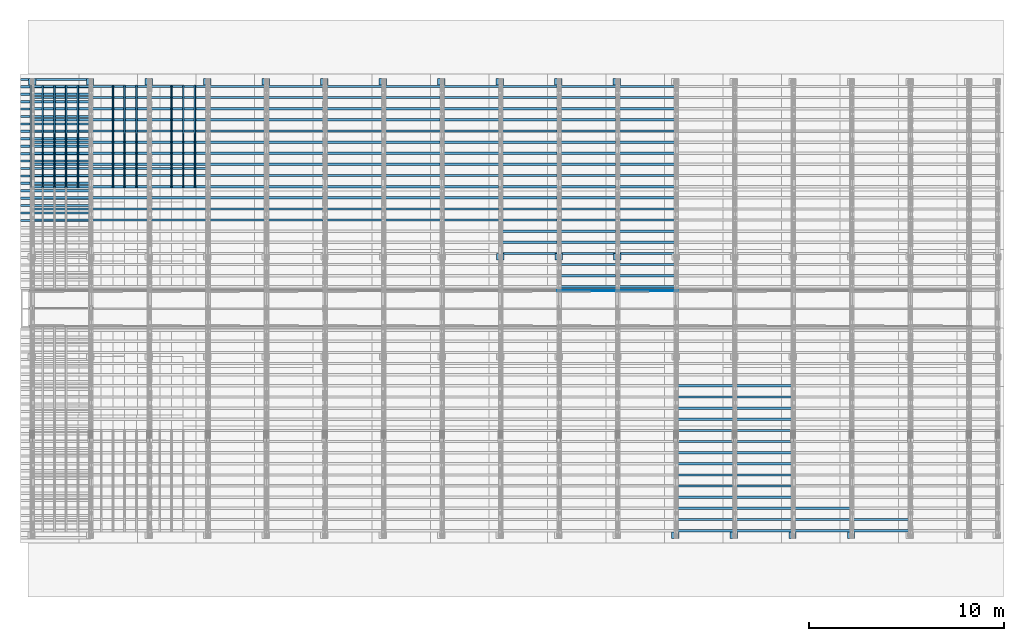
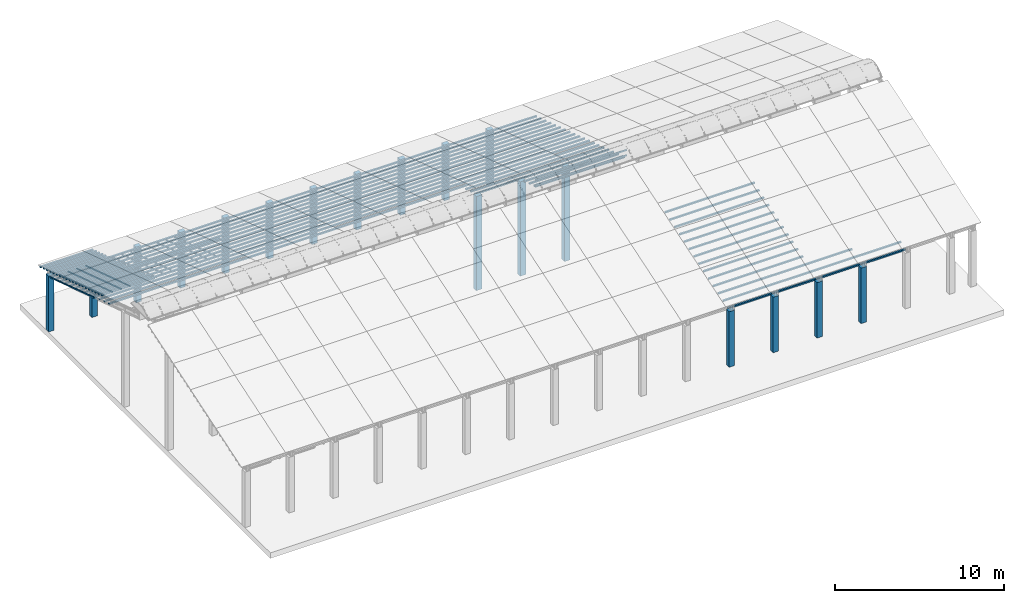
# One storey, part 3 of 385: 248 columns.
"""IFC2X3 building model written with IfcOpenShell, lengths in millimetres."""

from ifc_helpers import new_model, entity, si_unit, converted_unit, derived_unit, direction, frame, frame_2d, origin, origin_2d_with_axis, place, context, subcontext, project, spatial, rectangle, extrude, boolean, source, transform, mapped, material, type_object, type_shapes, element, save


model = new_model("IFC2X3")

# Units and contexts
model_context = context("Model", 3, precision=0.01, world=origin(), true_north=direction((6.12303176911189e-17, 1.0)))
body_context = subcontext(model_context, "Body", "Model", "MODEL_VIEW")
ifc_project = project(units=[si_unit("LENGTHUNIT", "METRE", prefix="MILLI"), si_unit("AREAUNIT", "SQUARE_METRE"), si_unit("VOLUMEUNIT", "CUBIC_METRE"), converted_unit("PLANEANGLEUNIT", "DEGREE", entity("IfcRatioMeasure", 0.0174532925199433), si_unit("PLANEANGLEUNIT", "RADIAN"), dimensions=[0, 0, 0, 0, 0, 0, 0]), si_unit("MASSUNIT", "GRAM", prefix="KILO"), derived_unit("MASSDENSITYUNIT", [(si_unit("MASSUNIT", "GRAM", prefix="KILO"), 1), (si_unit("LENGTHUNIT", "METRE"), -3)]), si_unit("TIMEUNIT", "SECOND"), si_unit("FREQUENCYUNIT", "HERTZ"), si_unit("THERMODYNAMICTEMPERATUREUNIT", "DEGREE_CELSIUS"), derived_unit("THERMALTRANSMITTANCEUNIT", [(si_unit("MASSUNIT", "GRAM", prefix="KILO"), 1), (si_unit("THERMODYNAMICTEMPERATUREUNIT", "KELVIN"), -1), (si_unit("TIMEUNIT", "SECOND"), -3)]), derived_unit("VOLUMETRICFLOWRATEUNIT", [(si_unit("LENGTHUNIT", "METRE"), 3), (si_unit("TIMEUNIT", "SECOND"), -1)]), si_unit("ELECTRICCURRENTUNIT", "AMPERE"), si_unit("ELECTRICVOLTAGEUNIT", "VOLT"), si_unit("POWERUNIT", "WATT"), si_unit("FORCEUNIT", "NEWTON", prefix="KILO"), si_unit("ILLUMINANCEUNIT", "LUX"), si_unit("LUMINOUSFLUXUNIT", "LUMEN"), si_unit("LUMINOUSINTENSITYUNIT", "CANDELA"), derived_unit("USERDEFINED", [(si_unit("MASSUNIT", "GRAM", prefix="KILO"), -1), (si_unit("LENGTHUNIT", "METRE"), -2), (si_unit("TIMEUNIT", "SECOND"), 3), (si_unit("LUMINOUSFLUXUNIT", "LUMEN"), 1)]), derived_unit("LINEARVELOCITYUNIT", [(si_unit("LENGTHUNIT", "METRE"), 1), (si_unit("TIMEUNIT", "SECOND"), -1)]), si_unit("PRESSUREUNIT", "PASCAL"), derived_unit("USERDEFINED", [(si_unit("LENGTHUNIT", "METRE"), -2), (si_unit("MASSUNIT", "GRAM", prefix="KILO"), 1), (si_unit("TIMEUNIT", "SECOND"), -2)])], contexts=[model_context])

# Site, building, storey
site_placement = place(None, origin())
site = spatial("IfcSite", under=ifc_project, at=site_placement, CompositionType="ELEMENT")
building_placement = place(site_placement, origin())
building = spatial("IfcBuilding", under=site, at=building_placement, CompositionType="ELEMENT")
storey_placement = place(building_placement, origin())
storey = spatial("IfcBuildingStorey", under=building, at=storey_placement, Name="Default", CompositionType="ELEMENT", Elevation=0.0)

# Columns
ifc_material_1 = material()
column_type_1 = type_object("IfcColumnType", Name="200x200", PredefinedType="COLUMN")
shared_shape_1 = source(origin(), body_context, "Body", "SweptSolid", [
    extrude(rectangle(XDim=379.999999999997, YDim=320.000000000004, at=origin_2d_with_axis()), frame((160.0, 300.0, -4000.0), z_axis=(0.0, 0.0, 1.0), x_axis=(0.0, -1.0, 0.0)), (0.0, 0.0, 1.0), 4000.0),
])
type_shapes(column_type_1, [shared_shape_1])
for number, where, z_axis, x_axis, name in (
    (1, (576.250000000001, 26180.0, 0.0), (0.0, 0.0, 1.0), (0.0, 1.0, 0.0), "V:200x200"),
    (2, (3535.0, 26180.0, 0.0), (0.0, 0.0, 1.0), (0.0, 1.0, 0.0), "V:200x200"),
    (3, (6535.0, 26180.0, 0.0), (0.0, 0.0, 1.0), (0.0, 1.0, 0.0), "V:200x200"),
    (4, (9535.0, 26180.0, 0.0), (0.0, 0.0, 1.0), (0.0, 1.0, 0.0), "V:200x200"),
    (5, (12535.0, 26180.0, 0.0), (0.0, 0.0, 1.0), (0.0, 1.0, 0.0), "V:200x200"),
    (6, (15535.0, 26180.0, 0.0), (0.0, 0.0, 1.0), (0.0, 1.0, 0.0), "V:200x200"),
    (7, (18535.0, 26180.0, 0.0), (0.0, 0.0, 1.0), (0.0, 1.0, 0.0), "V:200x200"),
    (8, (21535.0, 26180.0, 0.0), (0.0, 0.0, 1.0), (0.0, 1.0, 0.0), "V:200x200"),
    (9, (24535.0, 26180.0, 0.0), (0.0, 0.0, 1.0), (0.0, 1.0, 0.0), "V:200x200"),
    (10, (27535.0, 26180.0, 0.0), (0.0, 0.0, 1.0), (0.0, 1.0, 0.0), "V:200x200"),
    (11, (30535.0, 26180.0, 0.0), (0.0, 0.0, 1.0), (0.0, 1.0, 0.0), "V:200x200"),
    (12, (33535.0, 2940.0, 0.0), (0.0, 0.0, 1.0), (0.0, 1.0, 0.0), "V:200x200"),
    (13, (36535.0, 2940.0, 0.0), (0.0, 0.0, 1.0), (0.0, 1.0, 0.0), "V:200x200"),
    (14, (39535.0, 2940.0, 0.0), (0.0, 0.0, 1.0), (0.0, 1.0, 0.0), "V:200x200"),
    (15, (42535.0, 2940.0, 0.0), (0.0, 0.0, 1.0), (0.0, 1.0, 0.0), "V:200x200"),
):
    element("IfcColumn", number, at=place(storey_placement, frame(where, z_axis=z_axis, x_axis=x_axis)), inside=storey, type_object=column_type_1, material=ifc_material_1, Name=name, ObjectType="V:200x200", context=body_context, shape_type="MappedRepresentation", body=[
        mapped(shared_shape_1, transform((0.0, 0.0, 0.0), scale=1.0)),
    ])
column_type_2 = type_object("IfcColumnType", Name="200x200", PredefinedType="COLUMN")
shared_shape_2 = source(origin(), body_context, "Body", "SweptSolid", [
    extrude(rectangle(XDim=379.999999999997, YDim=320.000000000004, at=origin_2d_with_axis()), frame((160.0, 300.0, -4000.0), z_axis=(0.0, 0.0, 1.0), x_axis=(0.0, -1.0, 0.0)), (0.0, 0.0, 1.0), 6794.3),
])
type_shapes(column_type_2, [shared_shape_2])
for number, where, z_axis, x_axis, name in (
    (16, (24550.0, 17220.0, 0.0), (0.0, 0.0, 1.0), (0.0, 1.0, 0.0), "V:200x200"),
    (17, (27550.0, 17220.0, 0.0), (0.0, 0.0, 1.0), (0.0, 1.0, 0.0), "V:200x200"),
    (18, (30550.0, 17220.0, 0.0), (0.0, 0.0, 1.0), (0.0, 1.0, 0.0), "V:200x200"),
):
    element("IfcColumn", number, at=place(storey_placement, frame(where, z_axis=z_axis, x_axis=x_axis)), inside=storey, type_object=column_type_2, material=ifc_material_1, Name=name, ObjectType="V:200x200", context=body_context, shape_type="MappedRepresentation", body=[
        mapped(shared_shape_2, transform((0.0, 0.0, 0.0), scale=1.0)),
    ])
ifc_material_2 = material(Name="2")
column_type_3 = type_object("IfcColumnType", Name="100x70", PredefinedType="COLUMN")
shared_shape_3 = source(origin(), body_context, "Body", "CSG", [
    boolean("DIFFERENCE", extrude(rectangle(XDim=3612.2975905123, YDim=116.736841236773, at=origin_2d_with_axis()), frame((1806.14879525615, 145.11006420193, -28.6286403914129)), (0.0, 0.0, 1.0), 97.4756555803792), extrude(rectangle(XDim=70.0000000018648, YDim=100.00000000027, at=frame_2d((0.0, 3.5527136788005e-15), x_axis=(0.0, 1.0))), frame((3612.2975905123, 145.11006420193, 20.1091873987768), z_axis=(1.0, 0.0, 0.0), x_axis=(0.0, 0.951056516293611, -0.309016994379696)), (0.0, 0.0, -1.0), 3612.2975905123)),
])
type_shapes(column_type_3, [shared_shape_3])
for number, where, name in (
    (19, (-325.267643336502, 26317.9847769485, 628.753486115588), "H_28_35_gradi:100x70"),
    (20, (-325.267643336503, 25937.5621704304, 752.360283865566), "H_28_35_gradi:100x70"),
    (21, (-325.267643336503, 25557.1395639124, 875.967081615544), "H_28_35_gradi:100x70"),
    (22, (-325.267643336504, 25176.7169573943, 999.573879365521), "H_28_35_gradi:100x70"),
    (23, (-325.267643336505, 24796.2943508762, 1123.1806771155), "H_28_35_gradi:100x70"),
    (24, (-325.267643336505, 24415.8717443582, 1246.78747486548), "H_28_35_gradi:100x70"),
    (25, (-325.267643336506, 24035.4491378401, 1370.39427261545), "H_28_35_gradi:100x70"),
    (26, (-325.267643336507, 23655.0265313221, 1494.00107036543), "H_28_35_gradi:100x70"),
    (27, (-325.267643336507, 23274.603924804, 1617.60786811541), "H_28_35_gradi:100x70"),
    (28, (-325.267643336508, 22894.1813182859, 1741.21466586539), "H_28_35_gradi:100x70"),
    (29, (-325.267643336509, 22513.7587117679, 1864.82146361537), "H_28_35_gradi:100x70"),
    (30, (-325.267643336509, 22133.3361052498, 1988.42826136534), "H_28_35_gradi:100x70"),
    (31, (-325.26764333651, 21752.9134987318, 2112.03505911532), "H_28_35_gradi:100x70"),
    (32, (-325.26764333651, 21372.4908922137, 2235.6418568653), "H_28_35_gradi:100x70"),
    (33, (-325.267643336511, 20992.0682856956, 2359.24865461528), "H_28_35_gradi:100x70"),
    (34, (-325.267643336512, 20611.6456791776, 2482.85545236525), "H_28_35_gradi:100x70"),
    (35, (-325.267643336512, 20231.2230726595, 2606.46225011523), "H_28_35_gradi:100x70"),
    (36, (-325.267643336513, 19850.8004661415, 2730.06904786521), "H_28_35_gradi:100x70"),
    (37, (-325.267643336514, 19470.3778596234, 2853.67584561518), "H_28_35_gradi:100x70"),
    (38, (-325.267643336514, 19089.9552531053, 2977.28264336516), "H_28_35_gradi:100x70"),
    (39, (2674.73235666349, 21752.9134987317, 2112.03505911532), "H_28_35_gradi:100x70"),
    (40, (5674.73235666349, 21752.9134987317, 2112.03505911532), "H_28_35_gradi:100x70"),
):
    element("IfcColumn", number, at=place(storey_placement, frame(where)), inside=storey, type_object=column_type_3, material=ifc_material_2, Name=name, ObjectType="H_28_35_gradi:100x70", context=body_context, shape_type="MappedRepresentation", body=[
        mapped(shared_shape_3, transform((0.0, 0.0, 0.0), scale=1.0)),
    ])
column_type_4 = type_object("IfcColumnType", Name="100x70", PredefinedType="COLUMN")
shared_shape_4 = source(origin(), body_context, "Body", "CSG", [
    boolean("DIFFERENCE", extrude(rectangle(XDim=3112.0299471758, YDim=116.736841236773, at=origin_2d_with_axis()), frame((1556.0149735879, 145.11006420193, -28.6286403914128)), (0.0, 0.0, 1.0), 97.4756555803792), extrude(rectangle(XDim=70.0000000018648, YDim=100.00000000027, at=frame_2d((0.0, 3.5527136788005e-15), x_axis=(0.0, 1.0))), frame((3112.0299471758, 145.11006420193, 20.1091873987768), z_axis=(1.0, 0.0, 0.0), x_axis=(0.0, 0.951056516293611, -0.309016994379696)), (0.0, 0.0, -1.0), 3112.0299471758)),
])
type_shapes(column_type_4, [shared_shape_4])
column_placement = place(storey_placement, frame((175.0, 25956.5215151797, -37.9453157522206)))
element("IfcColumn", 41, at=column_placement, inside=storey, type_object=column_type_4, material=ifc_material_2, Name="H_28_35_gradi:100x70", ObjectType="H_28_35_gradi:100x70", context=body_context, shape_type="MappedRepresentation", body=[
    mapped(shared_shape_4, transform((0.0, 0.0, 0.0), scale=1.0)),
])
for number, where, name in (
    (42, (175.0, 25385.8876054039, 147.464880876897), "H_28_35_gradi:100x70"),
    (43, (175.0, 24815.253695627, 332.8750775022), "H_28_35_gradi:100x70"),
    (44, (175.0, 24244.6197858499, 518.285274127168), "H_28_35_gradi:100x70"),
    (45, (175.0, 23673.9858760728, 703.695470752224), "H_28_35_gradi:100x70"),
    (46, (175.0, 23103.3519662957, 889.105667377245), "H_28_35_gradi:100x70"),
    (47, (175.0, 22532.7180565186, 1074.51586400227), "H_28_35_gradi:100x70"),
    (48, (175.0, 21962.0841467416, 1259.92606062729), "H_28_35_gradi:100x70"),
    (49, (175.0, 21391.4502369645, 1445.33625725232), "H_28_35_gradi:100x70"),
    (50, (175.0, 20820.8163271874, 1630.74645387734), "H_28_35_gradi:100x70"),
    (51, (175.0, 20250.1824174103, 1816.15665050237), "H_28_35_gradi:100x70"),
    (52, (175.0, 19679.5485076333, 2001.56684712739), "H_28_35_gradi:100x70"),
    (53, (175.0, 19108.9145978562, 2186.97704375242), "H_28_35_gradi:100x70"),
):
    element("IfcColumn", number, at=place(building_placement, frame(where)), inside=storey, type_object=column_type_4, material=ifc_material_2, Name=name, ObjectType="H_28_35_gradi:100x70", context=body_context, shape_type="MappedRepresentation", body=[
        mapped(shared_shape_4, transform((0.0, 0.0, 0.0), scale=1.0)),
    ])
for number, where, name in (
    (54, (3175.0, 25956.5215151797, -37.9453157522206), "H_28_35_gradi:100x70"),
    (55, (3175.0, 25385.8876054039, 147.464880876897), "H_28_35_gradi:100x70"),
    (56, (3175.0, 24815.2536956269, 332.8750775022), "H_28_35_gradi:100x70"),
    (57, (3175.0, 24244.6197858498, 518.285274127168), "H_28_35_gradi:100x70"),
    (58, (3175.0, 23673.9858760728, 703.695470752224), "H_28_35_gradi:100x70"),
    (59, (3175.0, 23103.3519662957, 889.105667377245), "H_28_35_gradi:100x70"),
    (60, (3175.0, 22532.7180565186, 1074.51586400227), "H_28_35_gradi:100x70"),
    (61, (3175.0, 21962.0841467416, 1259.92606062729), "H_28_35_gradi:100x70"),
    (62, (3175.0, 21391.4502369645, 1445.33625725232), "H_28_35_gradi:100x70"),
    (63, (3175.0, 20820.8163271874, 1630.74645387734), "H_28_35_gradi:100x70"),
    (64, (3175.0, 20250.1824174103, 1816.15665050237), "H_28_35_gradi:100x70"),
    (65, (3175.0, 19679.5485076333, 2001.56684712739), "H_28_35_gradi:100x70"),
    (66, (3175.0, 19108.9145978562, 2186.97704375242), "H_28_35_gradi:100x70"),
    (67, (6175.0, 25956.5215151797, -37.9453157522206), "H_28_35_gradi:100x70"),
    (68, (6175.0, 25385.8876054039, 147.464880876897), "H_28_35_gradi:100x70"),
    (69, (6175.0, 24815.2536956269, 332.8750775022), "H_28_35_gradi:100x70"),
    (70, (6175.0, 24244.6197858498, 518.285274127168), "H_28_35_gradi:100x70"),
    (71, (6175.0, 23673.9858760728, 703.695470752224), "H_28_35_gradi:100x70"),
    (72, (6175.0, 23103.3519662957, 889.105667377245), "H_28_35_gradi:100x70"),
    (73, (6175.0, 22532.7180565186, 1074.51586400227), "H_28_35_gradi:100x70"),
    (74, (6175.0, 21962.0841467416, 1259.92606062729), "H_28_35_gradi:100x70"),
    (75, (6175.0, 21391.4502369645, 1445.33625725232), "H_28_35_gradi:100x70"),
    (76, (6175.0, 20820.8163271874, 1630.74645387734), "H_28_35_gradi:100x70"),
    (77, (6175.0, 20250.1824174103, 1816.15665050237), "H_28_35_gradi:100x70"),
    (78, (6175.0, 19679.5485076333, 2001.56684712739), "H_28_35_gradi:100x70"),
    (79, (6175.0, 19108.9145978562, 2186.97704375242), "H_28_35_gradi:100x70"),
    (80, (9175.0, 25956.5215151797, -37.9453157522206), "H_28_35_gradi:100x70"),
    (81, (9175.0, 25385.8876054039, 147.464880876897), "H_28_35_gradi:100x70"),
    (82, (9175.0, 24815.2536956269, 332.8750775022), "H_28_35_gradi:100x70"),
    (83, (9175.0, 24244.6197858498, 518.285274127168), "H_28_35_gradi:100x70"),
    (84, (9175.0, 23673.9858760728, 703.695470752224), "H_28_35_gradi:100x70"),
    (85, (9175.0, 23103.3519662957, 889.105667377245), "H_28_35_gradi:100x70"),
    (86, (9175.0, 22532.7180565186, 1074.51586400227), "H_28_35_gradi:100x70"),
    (87, (9175.0, 21962.0841467415, 1259.92606062729), "H_28_35_gradi:100x70"),
    (88, (9175.0, 21391.4502369645, 1445.33625725232), "H_28_35_gradi:100x70"),
    (89, (9175.0, 20820.8163271874, 1630.74645387734), "H_28_35_gradi:100x70"),
    (90, (9175.0, 20250.1824174103, 1816.15665050237), "H_28_35_gradi:100x70"),
    (91, (9175.0, 19679.5485076332, 2001.56684712739), "H_28_35_gradi:100x70"),
    (92, (9175.0, 19108.9145978562, 2186.97704375242), "H_28_35_gradi:100x70"),
    (93, (12175.0, 25956.5215151796, -37.9453157522206), "H_28_35_gradi:100x70"),
    (94, (12175.0, 25385.8876054039, 147.464880876897), "H_28_35_gradi:100x70"),
    (95, (12175.0, 24815.2536956269, 332.8750775022), "H_28_35_gradi:100x70"),
    (96, (12175.0, 24244.6197858498, 518.285274127168), "H_28_35_gradi:100x70"),
    (97, (12175.0, 23673.9858760728, 703.695470752224), "H_28_35_gradi:100x70"),
    (98, (12175.0, 23103.3519662957, 889.105667377245), "H_28_35_gradi:100x70"),
    (99, (12175.0, 22532.7180565186, 1074.51586400227), "H_28_35_gradi:100x70"),
    (100, (12175.0, 21962.0841467415, 1259.92606062729), "H_28_35_gradi:100x70"),
    (101, (12175.0, 21391.4502369645, 1445.33625725232), "H_28_35_gradi:100x70"),
    (102, (12175.0, 20820.8163271874, 1630.74645387734), "H_28_35_gradi:100x70"),
    (103, (12175.0, 20250.1824174103, 1816.15665050237), "H_28_35_gradi:100x70"),
    (104, (12175.0, 19679.5485076332, 2001.56684712739), "H_28_35_gradi:100x70"),
    (105, (12175.0, 19108.9145978562, 2186.97704375242), "H_28_35_gradi:100x70"),
    (106, (15175.0, 25956.5215151796, -37.9453157522206), "H_28_35_gradi:100x70"),
    (107, (15175.0, 25385.8876054039, 147.464880876897), "H_28_35_gradi:100x70"),
    (108, (15175.0, 24815.2536956269, 332.8750775022), "H_28_35_gradi:100x70"),
    (109, (15175.0, 24244.6197858498, 518.285274127168), "H_28_35_gradi:100x70"),
    (110, (15175.0, 23673.9858760728, 703.695470752224), "H_28_35_gradi:100x70"),
    (111, (15175.0, 23103.3519662957, 889.105667377245), "H_28_35_gradi:100x70"),
    (112, (15175.0, 22532.7180565186, 1074.51586400227), "H_28_35_gradi:100x70"),
    (113, (15175.0, 21962.0841467415, 1259.92606062729), "H_28_35_gradi:100x70"),
    (114, (15175.0, 21391.4502369645, 1445.33625725232), "H_28_35_gradi:100x70"),
    (115, (15175.0, 20820.8163271874, 1630.74645387734), "H_28_35_gradi:100x70"),
    (116, (15175.0, 20250.1824174103, 1816.15665050237), "H_28_35_gradi:100x70"),
    (117, (15175.0, 19679.5485076332, 2001.56684712739), "H_28_35_gradi:100x70"),
    (118, (15175.0, 19108.9145978562, 2186.97704375242), "H_28_35_gradi:100x70"),
    (119, (18175.0, 25956.5215151796, -37.9453157522206), "H_28_35_gradi:100x70"),
    (120, (18175.0, 25385.8876054039, 147.464880876897), "H_28_35_gradi:100x70"),
    (121, (18175.0, 24815.2536956269, 332.8750775022), "H_28_35_gradi:100x70"),
    (122, (18175.0, 24244.6197858498, 518.285274127168), "H_28_35_gradi:100x70"),
    (123, (18175.0, 23673.9858760727, 703.695470752224), "H_28_35_gradi:100x70"),
    (124, (18175.0, 23103.3519662957, 889.105667377245), "H_28_35_gradi:100x70"),
    (125, (18175.0, 22532.7180565186, 1074.51586400227), "H_28_35_gradi:100x70"),
    (126, (18175.0, 21962.0841467415, 1259.92606062729), "H_28_35_gradi:100x70"),
    (127, (18175.0, 21391.4502369644, 1445.33625725232), "H_28_35_gradi:100x70"),
    (128, (18175.0, 20820.8163271874, 1630.74645387734), "H_28_35_gradi:100x70"),
    (129, (18175.0, 20250.1824174103, 1816.15665050237), "H_28_35_gradi:100x70"),
    (130, (18175.0, 19679.5485076332, 2001.56684712739), "H_28_35_gradi:100x70"),
    (131, (18175.0, 19108.9145978561, 2186.97704375242), "H_28_35_gradi:100x70"),
    (132, (21175.0, 25956.5215151796, -37.9453157522206), "H_28_35_gradi:100x70"),
    (133, (21175.0, 25385.8876054039, 147.464880876897), "H_28_35_gradi:100x70"),
    (134, (21175.0, 24815.2536956269, 332.8750775022), "H_28_35_gradi:100x70"),
    (135, (21175.0, 24244.6197858498, 518.285274127168), "H_28_35_gradi:100x70"),
    (136, (21175.0, 23673.9858760727, 703.695470752224), "H_28_35_gradi:100x70"),
    (137, (21175.0, 23103.3519662957, 889.105667377245), "H_28_35_gradi:100x70"),
    (138, (21175.0, 22532.7180565186, 1074.51586400227), "H_28_35_gradi:100x70"),
    (139, (21175.0, 21962.0841467415, 1259.92606062729), "H_28_35_gradi:100x70"),
    (140, (21175.0, 21391.4502369644, 1445.33625725232), "H_28_35_gradi:100x70"),
    (141, (21175.0, 20820.8163271874, 1630.74645387734), "H_28_35_gradi:100x70"),
    (142, (21175.0, 20250.1824174103, 1816.15665050237), "H_28_35_gradi:100x70"),
    (143, (21175.0, 19679.5485076332, 2001.56684712739), "H_28_35_gradi:100x70"),
    (144, (21175.0, 19108.9145978561, 2186.97704375242), "H_28_35_gradi:100x70"),
    (145, (24175.0, 25956.5215151796, -37.9453157522206), "H_28_35_gradi:100x70"),
    (146, (24175.0, 25385.8876054039, 147.464880876897), "H_28_35_gradi:100x70"),
    (147, (24175.0, 24815.2536956269, 332.8750775022), "H_28_35_gradi:100x70"),
    (148, (24175.0, 24244.6197858498, 518.285274127168), "H_28_35_gradi:100x70"),
    (149, (24175.0, 23673.9858760727, 703.695470752224), "H_28_35_gradi:100x70"),
    (150, (24175.0, 23103.3519662957, 889.105667377245), "H_28_35_gradi:100x70"),
    (151, (24175.0, 22532.7180565186, 1074.51586400227), "H_28_35_gradi:100x70"),
    (152, (24175.0, 21962.0841467415, 1259.92606062729), "H_28_35_gradi:100x70"),
    (153, (24175.0, 21391.4502369644, 1445.33625725232), "H_28_35_gradi:100x70"),
    (154, (24175.0, 20820.8163271873, 1630.74645387734), "H_28_35_gradi:100x70"),
    (155, (24175.0, 20250.1824174103, 1816.15665050237), "H_28_35_gradi:100x70"),
    (156, (24175.0, 19679.5485076332, 2001.56684712739), "H_28_35_gradi:100x70"),
    (157, (24175.0, 19108.9145978561, 2186.97704375242), "H_28_35_gradi:100x70"),
    (158, (24175.0, 18538.2806880791, 2372.38724037744), "H_28_35_gradi:100x70"),
    (159, (24175.0, 17967.646778302, 2557.79743700247), "H_28_35_gradi:100x70"),
    (160, (24175.0, 17397.0128685249, 2743.20763362749), "H_28_35_gradi:100x70"),
    (161, (27175.0, 25956.5215151796, -37.9453157522206), "H_28_35_gradi:100x70"),
    (162, (27175.0, 25385.8876054039, 147.464880876897), "H_28_35_gradi:100x70"),
    (163, (27175.0, 24815.2536956269, 332.8750775022), "H_28_35_gradi:100x70"),
    (164, (27175.0, 24244.6197858498, 518.285274127168), "H_28_35_gradi:100x70"),
    (165, (27175.0, 23673.9858760727, 703.695470752224), "H_28_35_gradi:100x70"),
    (166, (27175.0, 23103.3519662956, 889.105667377245), "H_28_35_gradi:100x70"),
    (167, (27175.0, 22532.7180565186, 1074.51586400227), "H_28_35_gradi:100x70"),
    (168, (27175.0, 21962.0841467415, 1259.92606062729), "H_28_35_gradi:100x70"),
    (169, (27175.0, 21391.4502369644, 1445.33625725232), "H_28_35_gradi:100x70"),
    (170, (27175.0, 20820.8163271873, 1630.74645387734), "H_28_35_gradi:100x70"),
    (171, (27175.0, 20250.1824174103, 1816.15665050237), "H_28_35_gradi:100x70"),
    (172, (27175.0, 19679.5485076332, 2001.56684712739), "H_28_35_gradi:100x70"),
    (173, (27175.0, 19108.9145978561, 2186.97704375242), "H_28_35_gradi:100x70"),
    (174, (27175.0, 18538.280688079, 2372.38724037744), "H_28_35_gradi:100x70"),
    (175, (27175.0, 17967.646778302, 2557.79743700247), "H_28_35_gradi:100x70"),
    (176, (27175.0, 17397.0128685249, 2743.20763362749), "H_28_35_gradi:100x70"),
    (177, (27175.0, 16826.3789587478, 2928.61783025252), "H_28_35_gradi:100x70"),
    (178, (27175.0, 16255.7450489708, 3114.02802687754), "H_28_35_gradi:100x70"),
    (179, (27175.0, 15685.1111391937, 3299.43822350257), "H_28_35_gradi:100x70"),
    (180, (27175.0, 15551.9632269124, 3342.70060271507), "H_28_35_gradi:100x70"),
    (181, (30175.0, 25956.5215151796, -37.9453157522206), "H_28_35_gradi:100x70"),
    (182, (30175.0, 25385.8876054038, 147.464880876897), "H_28_35_gradi:100x70"),
    (183, (30175.0, 24815.2536956269, 332.8750775022), "H_28_35_gradi:100x70"),
    (184, (30175.0, 24244.6197858498, 518.285274127168), "H_28_35_gradi:100x70"),
    (185, (30175.0, 23673.9858760727, 703.695470752224), "H_28_35_gradi:100x70"),
    (186, (30175.0, 23103.3519662956, 889.105667377245), "H_28_35_gradi:100x70"),
    (187, (30175.0, 22532.7180565186, 1074.51586400227), "H_28_35_gradi:100x70"),
    (188, (30175.0, 21962.0841467415, 1259.92606062729), "H_28_35_gradi:100x70"),
    (189, (30175.0, 21391.4502369644, 1445.33625725232), "H_28_35_gradi:100x70"),
    (190, (30175.0, 20820.8163271873, 1630.74645387734), "H_28_35_gradi:100x70"),
    (191, (30175.0, 20250.1824174103, 1816.15665050237), "H_28_35_gradi:100x70"),
    (192, (30175.0, 19679.5485076332, 2001.56684712739), "H_28_35_gradi:100x70"),
    (193, (30175.0, 19108.9145978561, 2186.97704375242), "H_28_35_gradi:100x70"),
    (194, (30175.0, 18538.280688079, 2372.38724037744), "H_28_35_gradi:100x70"),
    (195, (30175.0, 17967.646778302, 2557.79743700247), "H_28_35_gradi:100x70"),
    (196, (30175.0, 17397.0128685249, 2743.20763362749), "H_28_35_gradi:100x70"),
    (197, (30175.0, 16826.3789587478, 2928.61783025252), "H_28_35_gradi:100x70"),
    (198, (30175.0, 16255.7450489707, 3114.02802687754), "H_28_35_gradi:100x70"),
    (199, (30175.0, 15685.1111391937, 3299.43822350257), "H_28_35_gradi:100x70"),
    (200, (30175.0, 15551.9632269124, 3342.70060271507), "H_28_35_gradi:100x70"),
):
    element("IfcColumn", number, at=place(storey_placement, frame(where)), inside=storey, type_object=column_type_4, material=ifc_material_2, Name=name, ObjectType="H_28_35_gradi:100x70", context=body_context, shape_type="MappedRepresentation", body=[
        mapped(shared_shape_4, transform((0.0, 0.0, 0.0), scale=1.0)),
    ])
column_type_5 = type_object("IfcColumnType", Name="45x70", PredefinedType="COLUMN")
shared_shape_5 = source(origin(), body_context, "Body", "SweptSolid", [
    extrude(rectangle(XDim=5484.52420681414, YDim=70.0, at=frame_2d((0.0, 0.0), x_axis=(0.0, 1.0))), frame((2608.04624283455, -237.823014276398, 847.405592983174), z_axis=(-0.309016994374947, 0.0, 0.951056516295154), x_axis=(0.0, 1.0, 0.0)), (0.0, 0.0, 1.0), 44.9999999999777),
])
type_shapes(column_type_5, [shared_shape_5])
for number, where, z_axis, x_axis, name in (
    (201, (447.823014276389, 26156.4255163017, -119.756735629718), (0.0, 0.0, 1.0), (0.0, -1.0, 0.0), "H:45x70"),
    (202, (1047.82301427639, 26156.4255163017, -119.756735629718), (0.0, 0.0, 1.0), (0.0, -1.0, 0.0), "H:45x70"),
    (203, (1647.82301427639, 26156.4255163017, -119.756735629718), (0.0, 0.0, 1.0), (0.0, -1.0, 0.0), "H:45x70"),
    (204, (2247.82301427639, 26156.4255163017, -119.756735629718), (0.0, 0.0, 1.0), (0.0, -1.0, 0.0), "H:45x70"),
    (205, (2847.82301427639, 26156.4255163017, -119.756735629718), (0.0, 0.0, 1.0), (0.0, -1.0, 0.0), "H:45x70"),
    (206, (4647.82301427639, 26156.4255163017, -119.756735629718), (0.0, 0.0, 1.0), (0.0, -1.0, 0.0), "H:45x70"),
    (207, (5247.82301427639, 26156.4255163017, -119.756735629718), (0.0, 0.0, 1.0), (0.0, -1.0, 0.0), "H:45x70"),
    (208, (5847.82301427639, 26156.4255163017, -119.756735629718), (0.0, 0.0, 1.0), (0.0, -1.0, 0.0), "H:45x70"),
    (209, (7647.82301427639, 26156.4255163017, -119.756735629718), (0.0, 0.0, 1.0), (0.0, -1.0, 0.0), "H:45x70"),
    (210, (8247.82301427639, 26156.4255163017, -119.756735629718), (0.0, 0.0, 1.0), (0.0, -1.0, 0.0), "H:45x70"),
    (211, (8847.82301427639, 26156.4255163017, -119.756735629718), (0.0, 0.0, 1.0), (0.0, -1.0, 0.0), "H:45x70"),
):
    element("IfcColumn", number, at=place(storey_placement, frame(where, z_axis=z_axis, x_axis=x_axis)), inside=storey, type_object=column_type_5, material=ifc_material_2, Name=name, ObjectType="H:45x70", context=body_context, shape_type="MappedRepresentation", body=[
        mapped(shared_shape_5, transform((0.0, 0.0, 0.0), scale=1.0)),
    ])
column_type_6 = type_object("IfcColumnType", Name="100x70", PredefinedType="COLUMN")
shared_shape_6 = source(origin(), body_context, "Body", "CSG", [
    boolean("DIFFERENCE", extrude(rectangle(XDim=3112.0299471758, YDim=116.736841236773, at=origin_2d_with_axis()), frame((1556.0149735879, -145.11006420193, -28.6286403914128)), (0.0, 0.0, 1.0), 97.4756555803792), extrude(rectangle(XDim=70.0000000018648, YDim=100.00000000027, at=frame_2d((0.0, 3.5527136788005e-15), x_axis=(0.0, 1.0))), frame((0.0, -145.11006420193, 20.1091873987768), z_axis=(-1.0, 0.0, 0.0), x_axis=(0.0, -0.951056516293611, -0.309016994379696)), (0.0, 0.0, -1.0), 3112.0299471758)),
])
type_shapes(column_type_6, [shared_shape_6])
for number, where, name in (
    (212, (33175.0, 3483.47831537052, -37.9453157522206), "H_28_35_gradi:100x70"),
    (213, (33175.0, 4054.11222514627, 147.464880876897), "H_28_35_gradi:100x70"),
    (214, (33175.0, 4624.74613492325, 332.8750775022), "H_28_35_gradi:100x70"),
    (215, (33175.0, 5195.38004470035, 518.285274127168), "H_28_35_gradi:100x70"),
    (216, (33175.0, 5766.01395447741, 703.695470752224), "H_28_35_gradi:100x70"),
    (217, (33175.0, 6336.64786425448, 889.105667377245), "H_28_35_gradi:100x70"),
    (218, (33175.0, 6907.28177403156, 1074.51586400227), "H_28_35_gradi:100x70"),
    (219, (33175.0, 7477.91568380864, 1259.92606062729), "H_28_35_gradi:100x70"),
    (220, (33175.0, 8048.54959358571, 1445.33625725232), "H_28_35_gradi:100x70"),
    (221, (33175.0, 8619.18350336279, 1630.74645387734), "H_28_35_gradi:100x70"),
    (222, (33175.0, 9189.81741313986, 1816.15665050237), "H_28_35_gradi:100x70"),
    (223, (33175.0, 9760.45132291694, 2001.56684712739), "H_28_35_gradi:100x70"),
    (224, (33175.0, 10331.085232694, 2186.97704375242), "H_28_35_gradi:100x70"),
    (225, (33175.0, 10901.7191424711, 2372.38724037744), "H_28_35_gradi:100x70"),
    (226, (36175.0, 3483.47831537051, -37.9453157522206), "H_28_35_gradi:100x70"),
    (227, (36175.0, 4054.11222514626, 147.464880876897), "H_28_35_gradi:100x70"),
    (228, (36175.0, 4624.74613492324, 332.8750775022), "H_28_35_gradi:100x70"),
    (229, (36175.0, 5195.38004470034, 518.285274127168), "H_28_35_gradi:100x70"),
    (230, (36175.0, 5766.0139544774, 703.695470752224), "H_28_35_gradi:100x70"),
    (231, (36175.0, 6336.64786425448, 889.105667377245), "H_28_35_gradi:100x70"),
    (232, (36175.0, 6907.28177403155, 1074.51586400227), "H_28_35_gradi:100x70"),
    (233, (36175.0, 7477.91568380863, 1259.92606062729), "H_28_35_gradi:100x70"),
    (234, (36175.0, 8048.5495935857, 1445.33625725232), "H_28_35_gradi:100x70"),
    (235, (36175.0, 8619.18350336278, 1630.74645387734), "H_28_35_gradi:100x70"),
    (236, (36175.0, 9189.81741313985, 1816.15665050237), "H_28_35_gradi:100x70"),
    (237, (36175.0, 9760.45132291694, 2001.56684712739), "H_28_35_gradi:100x70"),
    (238, (36175.0, 10331.085232694, 2186.97704375242), "H_28_35_gradi:100x70"),
    (239, (36175.0, 10901.7191424711, 2372.38724037744), "H_28_35_gradi:100x70"),
    (240, (39195.0, 3483.4783153705, -37.9453157522206), "H_28_35_gradi:100x70"),
    (241, (39195.0, 4054.11222514625, 147.464880876897), "H_28_35_gradi:100x70"),
    (242, (39195.0, 4624.74613492323, 332.8750775022), "H_28_35_gradi:100x70"),
    (243, (42195.0, 3483.4783153705, -37.9453157522206), "H_28_35_gradi:100x70"),
    (244, (42195.0, 4054.11222514624, 147.464880876897), "H_28_35_gradi:100x70"),
):
    element("IfcColumn", number, at=place(storey_placement, frame(where)), inside=storey, type_object=column_type_6, material=ifc_material_2, Name=name, ObjectType="H_28_35_gradi:100x70", context=body_context, shape_type="MappedRepresentation", body=[
        mapped(shared_shape_6, transform((0.0, 0.0, 0.0), scale=1.0)),
    ])
column_type_7 = type_object("IfcColumnType", Name="70x45", PredefinedType="COLUMN")
shared_shape_7 = source(origin(), body_context, "Body", "SweptSolid", [
    extrude(rectangle(XDim=45.0, YDim=3207.99969607346, at=frame_2d((-1.59872115546023e-14, 0.0), x_axis=(1.0, 0.0))), frame((1603.99984803673, 250.323014276398, 0.0), z_axis=(0.0, 0.0, 1.0), x_axis=(0.0, -1.0, 0.0)), (0.0, 0.0, 1.0), 69.9999999999776),
])
type_shapes(column_type_7, [shared_shape_7])
for number, where, z_axis, x_axis, name in (
    (245, (30382.9996960735, 15887.8230423367, 3436.65682464217), (0.0, 0.0, 1.0), (-1.0, 0.0, 0.0), "H1:70x45"),
    (246, (30382.9996960735, 15887.8230423367, 3821.65682464217), (0.0, 0.0, 1.0), (-1.0, 0.0, 0.0), "H1:70x45"),
    (247, (33382.9996960735, 15887.8230423367, 3436.65682464217), (0.0, 0.0, 1.0), (-1.0, 0.0, 0.0), "H1:70x45"),
    (248, (33382.9996960735, 15887.8230423367, 3821.65682464217), (0.0, 0.0, 1.0), (-1.0, 0.0, 0.0), "H1:70x45"),
):
    element("IfcColumn", number, at=place(storey_placement, frame(where, z_axis=z_axis, x_axis=x_axis)), inside=storey, type_object=column_type_7, material=ifc_material_2, Name=name, ObjectType="H1:70x45", context=body_context, shape_type="MappedRepresentation", body=[
        mapped(shared_shape_7, transform((0.0, 0.0, 0.0), scale=1.0)),
    ])

save(model, "model.ifc")
